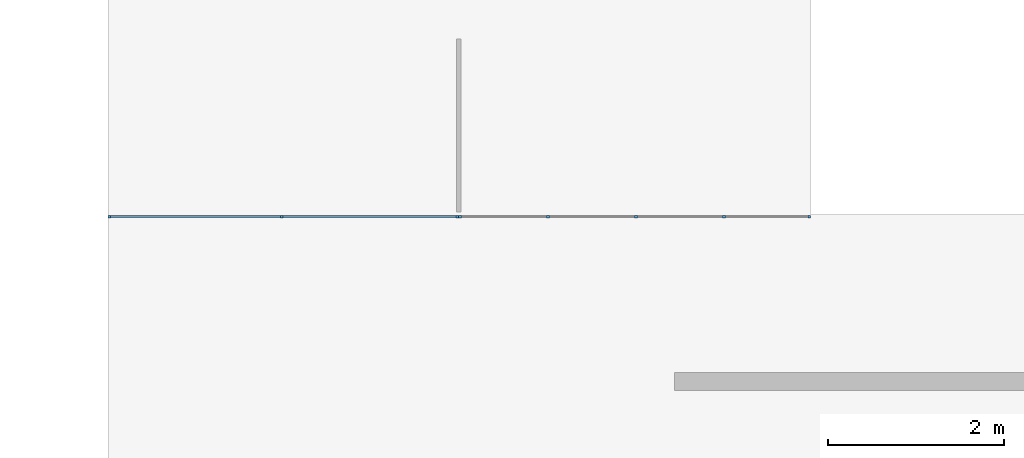
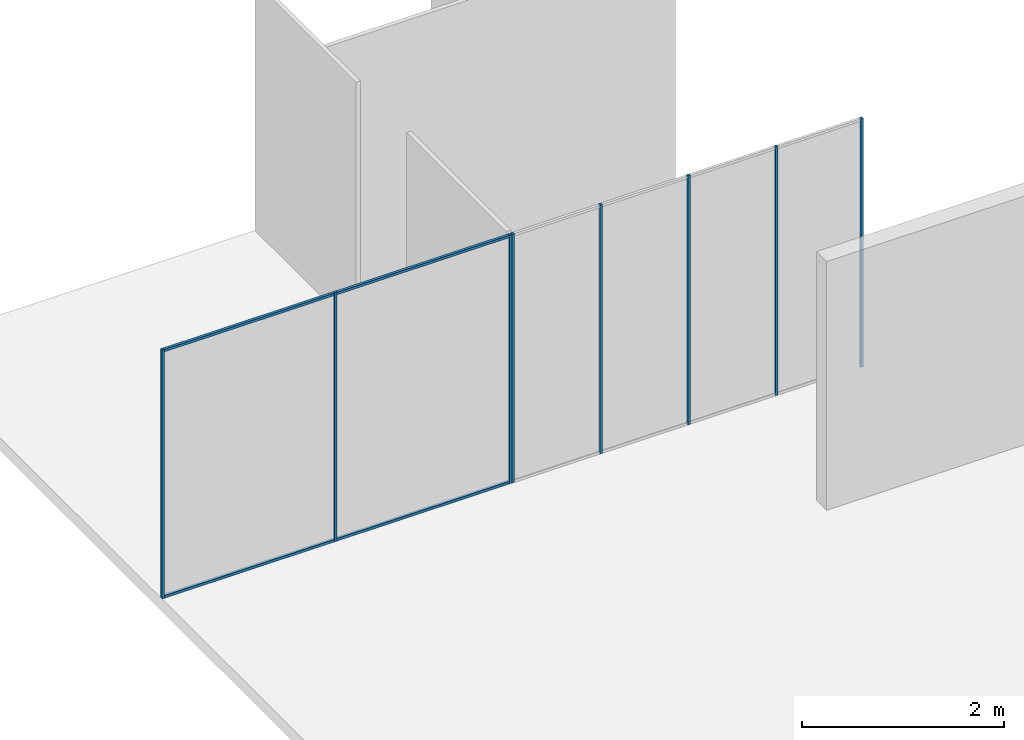
# One storey, part 2 of 8: 12 members, 2 elements without a shape of their own.
"""IFC2X3 building model written with IfcOpenShell, lengths in millimetres."""

from ifc_helpers import new_model, entity, si_unit, converted_unit, direction, frame, frame_2d, origin, origin_2d_with_axis, place, context, subcontext, project, spatial, rectangle, extrude, element, aggregate, save


model = new_model("IFC2X3")

# Units and contexts
model_context = context("Model", 3, precision=1e-06, world=origin(), true_north=direction((2.0, 6.12303176911189e-17, 1.0)))
context_of_model = context(None, 3, precision=1e-06, world=origin(), true_north=direction((2.0, 6.12303176911189e-17, 1.0)))
body_context = subcontext(model_context, "Body", "Model", "MODEL_VIEW")
ifc_project = project(units=[si_unit("LENGTHUNIT", "METRE", prefix="MILLI"), si_unit("AREAUNIT", "SQUARE_METRE", prefix="MILLI"), si_unit("VOLUMEUNIT", "CUBIC_METRE", prefix="MILLI"), converted_unit("PLANEANGLEUNIT", "DEGREE", entity("IfcRatioMeasure", 0.0174532925199433), si_unit("PLANEANGLEUNIT", "RADIAN"), dimensions=[0, 0, 0, 0, 0, 0, 0]), si_unit("TIMEUNIT", "SECOND")], contexts=[model_context, context_of_model])

# Site, building, storey
site_placement = place(None, origin())
site = spatial("IfcSite", under=ifc_project, at=site_placement, CompositionType="ELEMENT")
building_placement = place(site_placement, origin())
building = spatial("IfcBuilding", under=site, at=building_placement, CompositionType="ELEMENT")
storey_placement = place(building_placement, frame((0.0, 0.0, 1500.0)))
storey = spatial("IfcBuildingStorey", under=building, at=storey_placement, Name="Level 1", CompositionType="ELEMENT", Elevation=1500.0)

# Curtain wall, members
curtain_wall_1_placement = place(storey_placement, origin())
curtain_wall_1 = element("IfcCurtainWall", 1, at=curtain_wall_1_placement, inside=storey, Name="Curtain Wall:Curtain Wall", ObjectType="Curtain Wall:Curtain Wall:334")
member_1_placement = place(storey_placement, origin())
member_1 = element("IfcMember", 2, at=member_1_placement, Name="Curtain Wall:Curtain Wall:8490", ObjectType="Curtain Wall:Curtain Wall:8490", context=body_context, shape_type="SweptSolid", body=[
    extrude(rectangle(XDim=1936.24999999999, YDim=29.9999999999997, at=origin_2d_with_axis()), frame((-24001.875, 5875.0, 2970.0), z_axis=(0.0, 0.0, 1.0), x_axis=(-1.0, 0.0, 0.0)), (0.0, 0.0, 1.0), 30.0000000000002),
])
member_2_placement = place(storey_placement, origin())
member_2 = element("IfcMember", 3, at=member_2_placement, Name="Curtain Wall:Curtain Wall:8490", ObjectType="Curtain Wall:Curtain Wall:8490", context=body_context, shape_type="SweptSolid", body=[
    extrude(rectangle(XDim=1966.24999999999, YDim=29.9999999999997, at=frame_2d((2.1600499167107e-12, 0.0), x_axis=(1.0, 0.0))), frame((-22020.625, 5875.0, 0.0)), (0.0, 0.0, 1.0), 29.9999999999999),
])
member_3_placement = place(storey_placement, origin())
member_3 = element("IfcMember", 4, at=member_3_placement, Name="Curtain Wall:Curtain Wall:8490", ObjectType="Curtain Wall:Curtain Wall:8490", context=body_context, shape_type="SweptSolid", body=[
    extrude(rectangle(XDim=30.0000000000008, YDim=29.9999999999975, at=frame_2d((-5.41788836017076e-13, -2.16626716564861e-12), x_axis=(1.0, 0.0))), frame((-21022.5, 5875.0, 0.0), z_axis=(0.0, 0.0, 1.0), x_axis=(0.0, 1.0, 0.0)), (0.0, 0.0, 1.0), 3000.0),
])
member_4_placement = place(storey_placement, origin())
member_4 = element("IfcMember", 5, at=member_4_placement, Name="Curtain Wall:Curtain Wall:8490", ObjectType="Curtain Wall:Curtain Wall:8490", context=body_context, shape_type="SweptSolid", body=[
    extrude(rectangle(XDim=1936.24999999999, YDim=29.9999999999997, at=origin_2d_with_axis()), frame((-24001.875, 5875.0, 0.0)), (0.0, 0.0, 1.0), 29.9999999999999),
])
member_5_placement = place(storey_placement, origin())
member_5 = element("IfcMember", 6, at=member_5_placement, Name="Curtain Wall:Curtain Wall:8490", ObjectType="Curtain Wall:Curtain Wall:8490", context=body_context, shape_type="SweptSolid", body=[
    extrude(rectangle(XDim=1966.24999999999, YDim=29.9999999999997, at=frame_2d((2.1600499167107e-12, 0.0), x_axis=(1.0, 0.0))), frame((-22020.625, 5875.0, 2970.0), z_axis=(0.0, 0.0, 1.0), x_axis=(-1.0, 0.0, 0.0)), (0.0, 0.0, 1.0), 30.0000000000002),
])
member_6_placement = place(storey_placement, origin())
member_6 = element("IfcMember", 7, at=member_6_placement, Name="Curtain Wall:Curtain Wall:8490", ObjectType="Curtain Wall:Curtain Wall:8490", context=body_context, shape_type="SweptSolid", body=[
    extrude(rectangle(XDim=29.9999999999997, YDim=29.9999999999975, at=frame_2d((0.0, -2.16626716564861e-12), x_axis=(1.0, 0.0))), frame((-23018.75, 5875.0, 0.0), z_axis=(0.0, 0.0, 1.0), x_axis=(0.0, 1.0, 0.0)), (0.0, 0.0, 1.0), 3000.0),
])
member_7_placement = place(storey_placement, origin())
member_7 = element("IfcMember", 8, at=member_7_placement, Name="Curtain Wall:Curtain Wall:8490", ObjectType="Curtain Wall:Curtain Wall:8490", context=body_context, shape_type="SweptSolid", body=[
    extrude(rectangle(XDim=30.0000000000018, YDim=29.9999999999997, at=origin_2d_with_axis()), frame((-24985.0, 5875.0, 0.0)), (0.0, 0.0, 1.0), 3000.0),
])
aggregate(curtain_wall_1, [member_1, member_2, member_3, member_4, member_5, member_6, member_7])

curtain_wall_2_placement = place(storey_placement, origin())
curtain_wall_2 = element("IfcCurtainWall", 9, at=curtain_wall_2_placement, inside=storey, Name="Curtain Wall:Curtain Wall", ObjectType="Curtain Wall:Curtain Wall:334")
member_8_placement = place(storey_placement, origin())
member_8 = element("IfcMember", 10, at=member_8_placement, Name="Curtain Wall:Curtain Wall:8490", ObjectType="Curtain Wall:Curtain Wall:8490", context=body_context, shape_type="SweptSolid", body=[
    extrude(rectangle(XDim=29.9999999999997, YDim=29.9999999999997, at=frame_2d((0.0, -1.08268949361445e-12), x_axis=(1.0, 0.0))), frame((-17986.875, 5875.0, 0.0), z_axis=(0.0, 0.0, 1.0), x_axis=(0.0, 1.0, 0.0)), (0.0, 0.0, 1.0), 3000.0),
])
member_9_placement = place(storey_placement, origin())
member_9 = element("IfcMember", 11, at=member_9_placement, Name="Curtain Wall:Curtain Wall:8490", ObjectType="Curtain Wall:Curtain Wall:8490", context=body_context, shape_type="SweptSolid", body=[
    extrude(rectangle(XDim=29.9999999999997, YDim=29.9999999999997, at=frame_2d((0.0, 1.08268949361445e-12), x_axis=(1.0, 0.0))), frame((-18988.75, 5875.0, 0.0), z_axis=(0.0, 0.0, 1.0), x_axis=(0.0, 1.0, 0.0)), (0.0, 0.0, 1.0), 3000.0),
])
member_10_placement = place(storey_placement, origin())
member_10 = element("IfcMember", 12, at=member_10_placement, Name="Curtain Wall:Curtain Wall:8490", ObjectType="Curtain Wall:Curtain Wall:8490", context=body_context, shape_type="SweptSolid", body=[
    extrude(rectangle(XDim=29.9999999999997, YDim=29.9999999999975, at=frame_2d((0.0, -2.16626716564861e-12), x_axis=(1.0, 0.0))), frame((-19990.625, 5875.0, 0.0), z_axis=(0.0, 0.0, 1.0), x_axis=(0.0, 1.0, 0.0)), (0.0, 0.0, 1.0), 3000.0),
])
member_11_placement = place(storey_placement, origin())
member_11 = element("IfcMember", 13, at=member_11_placement, Name="Curtain Wall:Curtain Wall:8490", ObjectType="Curtain Wall:Curtain Wall:8490", context=body_context, shape_type="SweptSolid", body=[
    extrude(rectangle(XDim=30.0000000000008, YDim=29.9999999999997, at=frame_2d((-5.41788836017076e-13, 1.08268949361445e-12), x_axis=(1.0, 0.0))), frame((-17015.0, 5875.0, 0.0), z_axis=(0.0, 0.0, 1.0), x_axis=(0.0, 1.0, 0.0)), (0.0, 0.0, 1.0), 3000.0),
])
member_12_placement = place(storey_placement, origin())
member_12 = element("IfcMember", 14, at=member_12_placement, Name="Curtain Wall:Curtain Wall:8490", ObjectType="Curtain Wall:Curtain Wall:8490", context=body_context, shape_type="SweptSolid", body=[
    extrude(rectangle(XDim=30.0000000000018, YDim=29.9999999999997, at=origin_2d_with_axis()), frame((-20992.5, 5875.0, 0.0)), (0.0, 0.0, 1.0), 3000.0),
])
aggregate(curtain_wall_2, [member_8, member_9, member_10, member_11, member_12])

save(model, "model.ifc")
